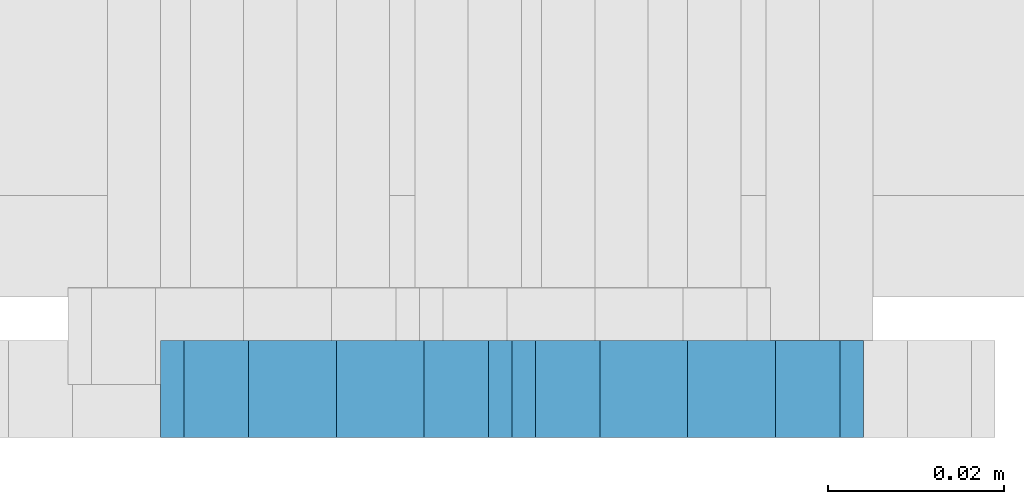
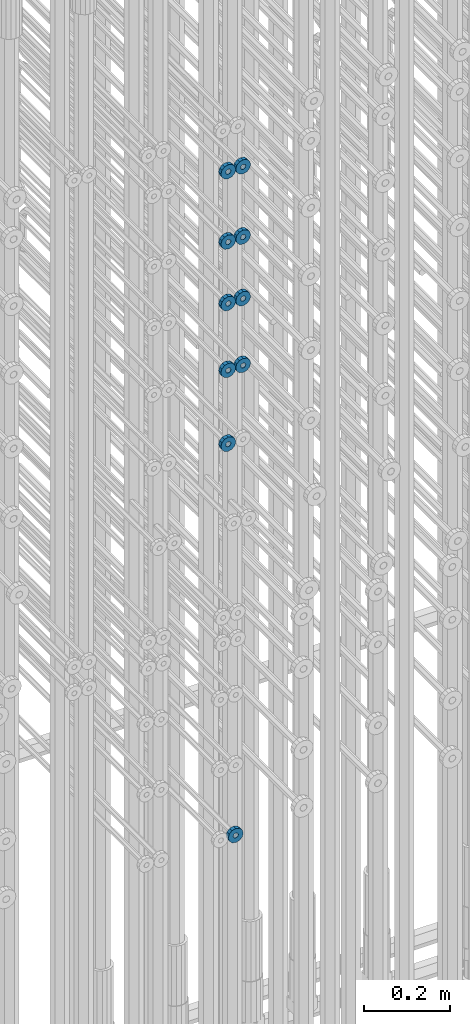
# One storey, part 135 of 177: 10 beams.
"""IFC2X3 building model written with IfcOpenShell, lengths in millimetres."""

from ifc_helpers import new_model, si_unit, frame, origin_with_axes, place, context, subcontext, project, spatial, faceted_brep, material, type_object, element, save


model = new_model("IFC2X3")

# Units and contexts
model_context_1 = context("Model", 3, precision=1e-05, world=origin_with_axes())
model_context_2 = context("Model", 3, precision=1e-05, world=origin_with_axes())
body_context = subcontext(model_context_2, "Body", "Model", "MODEL_VIEW")
ifc_project = project(units=[si_unit("LENGTHUNIT", "METRE", prefix="MILLI"), si_unit("AREAUNIT", "SQUARE_METRE"), si_unit("VOLUMEUNIT", "CUBIC_METRE"), si_unit("MASSUNIT", "GRAM", prefix="KILO"), si_unit("TIMEUNIT", "SECOND"), si_unit("PLANEANGLEUNIT", "RADIAN"), si_unit("SOLIDANGLEUNIT", "STERADIAN"), si_unit("THERMODYNAMICTEMPERATUREUNIT", "DEGREE_CELSIUS"), si_unit("LUMINOUSINTENSITYUNIT", "LUMEN")], contexts=[model_context_1])

# Site, building, storey
site_placement = place(None, origin_with_axes())
site = spatial("IfcSite", under=ifc_project, at=site_placement, CompositionType="ELEMENT")
building_placement = place(site_placement, origin_with_axes())
building = spatial("IfcBuilding", under=site, at=building_placement, Name="Undefined", CompositionType="ELEMENT")
storey_placement = place(building_placement, origin_with_axes())
storey = spatial("IfcBuildingStorey", under=building, at=storey_placement, Name="Undefined", CompositionType="ELEMENT", Elevation=0.0)

# Beams
ifc_material = material(Name="STEEL/Steel_Undefined")
beam_type = type_object("IfcBeamType", PredefinedType="NOTDEFINED")
beam_1_placement = place(storey_placement, frame((2031926.99847313, 6205070.98588034, 20239.9868114202), z_axis=(0.0, 0.0, -1.0), x_axis=(0.0, -1.0, 0.0)))
element("IfcBeam", 1, at=beam_1_placement, inside=storey, type_object=beam_type, material=ifc_material, context=body_context, shape_type="Brep", body=[
    faceted_brep([(-3.63797880709171e-12, -7.0, -2.3283064365387e-10), (-8.62348444298797e-13, -6.06217782649107, 3.5), (10.9999999999964, -6.06217782665044, 3.49999999976717), (10.9999999999964, -7.0, -2.3283064365387e-10), (-3.63797880709171e-12, -3.5, 6.06217782618478), (11.0, -3.5, 6.06217782618478), (-1.72469688859759e-12, 0.0, 7.0), (11.0, 0.0, 6.99999999976717), (-3.63797880709171e-12, 3.5, 6.06217782618478), (11.0, 3.5, 6.06217782618478), (-8.62348444298795e-13, 6.06217782649107, 3.5), (10.9999999999964, 6.06217782665044, 3.49999999976717), (-3.63797880709171e-12, 7.0, -2.3283064365387e-10), (10.9999999999964, 7.0, -2.3283064365387e-10), (8.62348444298797e-13, 6.06217782649107, -3.5), (10.9999999999964, 6.06217782665044, -3.50000000023283), (-3.63797880709171e-12, 3.5, -6.06217782665044), (10.9999999999964, 3.5, -6.06217782665044), (1.72469688859759e-12, -2.72004641033163e-15, -7.0), (10.9999999999964, 0.0, -7.00000000023283), (-3.63797880709171e-12, -3.5, -6.06217782665044), (10.9999999999964, -3.5, -6.06217782665044), (8.62348444298796e-13, -6.06217782649107, -3.5), (10.9999999999964, -6.06217782665044, -3.50000000023283), (0.0, -20.0000000009313, 0.0), (0.0, -17.320508075878, -10.0), (10.9999999999964, -17.320508075878, -10.0000000002328), (10.9999999999964, -20.0, -2.3283064365387e-10), (0.0, -10.0000000009313, -17.3205080756452), (11.0, -10.0, -17.320508075878), (0.0, -1.86264514923096e-09, -19.9999999998836), (10.9999999999964, 0.0, -20.0000000002328), (0.0, 9.99999999906868, -17.3205080755288), (11.0, 10.0, -17.320508075878), (0.0, 17.320508075878, -10.0), (10.9999999999964, 17.320508075878, -10.0000000002328), (0.0, 19.9999999990687, 0.0), (10.9999999999964, 20.0, -2.3283064365387e-10), (0.0, 17.3205080740154, 10.0), (11.0, 17.320508075878, 9.99999999976717), (0.0, 9.99999999906868, 17.3205080757616), (10.9999999999964, 10.0, 17.3205080754124), (0.0, 0.0, 20.0000000001164), (10.9999999999964, 0.0, 19.9999999997672), (0.0, -10.0000000009313, 17.3205080757616), (10.9999999999964, -10.0, 17.3205080754124), (0.0, -17.3205080777407, 10.0000000001164), (11.0, -17.320508075878, 9.99999999976717)], [[[0, 1, 2, 3]], [[1, 4, 5, 2]], [[4, 6, 7, 5]], [[6, 8, 9, 7]], [[8, 10, 11, 9]], [[10, 12, 13, 11]], [[12, 14, 15, 13]], [[14, 16, 17, 15]], [[16, 18, 19, 17]], [[18, 20, 21, 19]], [[20, 22, 23, 21]], [[22, 0, 3, 23]], [[24, 25, 26, 27]], [[25, 28, 29, 26]], [[28, 30, 31, 29]], [[30, 32, 33, 31]], [[32, 34, 35, 33]], [[34, 36, 37, 35]], [[36, 38, 39, 37]], [[38, 40, 41, 39]], [[40, 42, 43, 41]], [[42, 44, 45, 43]], [[44, 46, 47, 45]], [[46, 24, 27, 47]], [[29, 31, 33, 35, 37, 39, 41, 43, 45, 47, 27, 26], [5, 7, 9, 11, 13, 15, 17, 19, 21, 23, 3, 2]], [[46, 44, 42, 40, 38, 36, 34, 32, 30, 28, 25, 24], [22, 20, 18, 16, 14, 12, 10, 8, 6, 4, 1, 0]]]),
])
beam_2_placement = place(storey_placement, frame((2031906.99847313, 6205070.98588032, 22134.9868114202), z_axis=(0.0, 0.0, -1.0), x_axis=(0.0, -1.0, 0.0)))
element("IfcBeam", 2, at=beam_2_placement, inside=storey, type_object=beam_type, material=ifc_material, context=body_context, shape_type="Brep", body=[
    faceted_brep([(-3.63797880709171e-12, -7.0, -2.3283064365387e-10), (-8.62348444298797e-13, -6.06217782649107, 3.5), (10.9999999999964, -6.06217782665044, 3.49999999976717), (10.9999999999964, -7.0, -2.3283064365387e-10), (-3.63797880709171e-12, -3.5, 6.06217782618478), (11.0, -3.5, 6.06217782618478), (-1.72469688859759e-12, 0.0, 7.0), (11.0, 0.0, 6.99999999976717), (-3.63797880709171e-12, 3.5, 6.06217782618478), (11.0, 3.5, 6.06217782618478), (-8.62348444298795e-13, 6.06217782649107, 3.5), (10.9999999999964, 6.06217782665044, 3.49999999976717), (-3.63797880709171e-12, 7.0, -2.3283064365387e-10), (10.9999999999964, 7.0, -2.3283064365387e-10), (8.62348444298797e-13, 6.06217782649107, -3.5), (10.9999999999964, 6.06217782665044, -3.50000000023283), (-3.63797880709171e-12, 3.5, -6.06217782665044), (10.9999999999964, 3.5, -6.06217782665044), (1.72469688859759e-12, -2.72004641033163e-15, -7.0), (10.9999999999964, 0.0, -7.00000000023283), (-3.63797880709171e-12, -3.5, -6.06217782665044), (10.9999999999964, -3.5, -6.06217782665044), (8.62348444298796e-13, -6.06217782649107, -3.5), (10.9999999999964, -6.06217782665044, -3.50000000023283), (0.0, -20.0000000009313, 0.0), (0.0, -17.320508075878, -10.0), (10.9999999999964, -17.320508075878, -10.0000000002328), (10.9999999999964, -20.0, -2.3283064365387e-10), (0.0, -10.0000000009313, -17.3205080756452), (11.0, -10.0, -17.320508075878), (0.0, -1.86264514923096e-09, -19.9999999998836), (10.9999999999964, 0.0, -20.0000000002328), (0.0, 9.99999999906868, -17.3205080755288), (11.0, 10.0, -17.320508075878), (0.0, 17.320508075878, -10.0), (10.9999999999964, 17.320508075878, -10.0000000002328), (0.0, 19.9999999990687, 0.0), (10.9999999999964, 20.0, -2.3283064365387e-10), (0.0, 17.3205080740154, 10.0), (11.0, 17.320508075878, 9.99999999976717), (0.0, 9.99999999906868, 17.3205080757616), (10.9999999999964, 10.0, 17.3205080754124), (0.0, 0.0, 20.0000000001164), (10.9999999999964, 0.0, 19.9999999997672), (0.0, -10.0000000009313, 17.3205080757616), (10.9999999999964, -10.0, 17.3205080754124), (0.0, -17.3205080777407, 10.0000000001164), (11.0, -17.320508075878, 9.99999999976717)], [[[0, 1, 2, 3]], [[1, 4, 5, 2]], [[4, 6, 7, 5]], [[6, 8, 9, 7]], [[8, 10, 11, 9]], [[10, 12, 13, 11]], [[12, 14, 15, 13]], [[14, 16, 17, 15]], [[16, 18, 19, 17]], [[18, 20, 21, 19]], [[20, 22, 23, 21]], [[22, 0, 3, 23]], [[24, 25, 26, 27]], [[25, 28, 29, 26]], [[28, 30, 31, 29]], [[30, 32, 33, 31]], [[32, 34, 35, 33]], [[34, 36, 37, 35]], [[36, 38, 39, 37]], [[38, 40, 41, 39]], [[40, 42, 43, 41]], [[42, 44, 45, 43]], [[44, 46, 47, 45]], [[46, 24, 27, 47]], [[29, 31, 33, 35, 37, 39, 41, 43, 45, 47, 27, 26], [5, 7, 9, 11, 13, 15, 17, 19, 21, 23, 3, 2]], [[46, 44, 42, 40, 38, 36, 34, 32, 30, 28, 25, 24], [22, 20, 18, 16, 14, 12, 10, 8, 6, 4, 1, 0]]]),
])
beam_3_placement = place(storey_placement, frame((2031946.99847313, 6205070.98588032, 22134.9868114202), z_axis=(0.0, 0.0, -1.0), x_axis=(0.0, -1.0, 0.0)))
element("IfcBeam", 3, at=beam_3_placement, inside=storey, type_object=beam_type, material=ifc_material, context=body_context, shape_type="Brep", body=[
    faceted_brep([(-3.63797880709171e-12, -7.0, -2.3283064365387e-10), (-8.62348444298797e-13, -6.06217782649107, 3.5), (10.9999999999964, -6.06217782665044, 3.49999999976717), (10.9999999999964, -7.0, -2.3283064365387e-10), (-3.63797880709171e-12, -3.5, 6.06217782618478), (11.0, -3.5, 6.06217782618478), (-1.72469688859759e-12, 0.0, 7.0), (11.0, 0.0, 6.99999999976717), (-3.63797880709171e-12, 3.5, 6.06217782618478), (11.0, 3.5, 6.06217782618478), (-8.62348444298795e-13, 6.06217782649107, 3.5), (10.9999999999964, 6.06217782665044, 3.49999999976717), (-3.63797880709171e-12, 7.0, -2.3283064365387e-10), (10.9999999999964, 7.0, -2.3283064365387e-10), (8.62348444298797e-13, 6.06217782649107, -3.5), (10.9999999999964, 6.06217782665044, -3.50000000023283), (-3.63797880709171e-12, 3.5, -6.06217782665044), (10.9999999999964, 3.5, -6.06217782665044), (1.72469688859759e-12, -2.72004641033163e-15, -7.0), (10.9999999999964, 0.0, -7.00000000023283), (-3.63797880709171e-12, -3.5, -6.06217782665044), (10.9999999999964, -3.5, -6.06217782665044), (8.62348444298796e-13, -6.06217782649107, -3.5), (10.9999999999964, -6.06217782665044, -3.50000000023283), (0.0, -20.0000000009313, 0.0), (0.0, -17.320508075878, -10.0), (10.9999999999964, -17.320508075878, -10.0000000002328), (10.9999999999964, -20.0, -2.3283064365387e-10), (0.0, -10.0000000009313, -17.3205080756452), (11.0, -10.0, -17.320508075878), (0.0, -1.86264514923096e-09, -19.9999999998836), (10.9999999999964, 0.0, -20.0000000002328), (0.0, 9.99999999906868, -17.3205080755288), (11.0, 10.0, -17.320508075878), (0.0, 17.320508075878, -10.0), (10.9999999999964, 17.320508075878, -10.0000000002328), (0.0, 19.9999999990687, 0.0), (10.9999999999964, 20.0, -2.3283064365387e-10), (0.0, 17.3205080740154, 10.0), (11.0, 17.320508075878, 9.99999999976717), (0.0, 9.99999999906868, 17.3205080757616), (10.9999999999964, 10.0, 17.3205080754124), (0.0, 0.0, 20.0000000001164), (10.9999999999964, 0.0, 19.9999999997672), (0.0, -10.0000000009313, 17.3205080757616), (10.9999999999964, -10.0, 17.3205080754124), (0.0, -17.3205080777407, 10.0000000001164), (11.0, -17.320508075878, 9.99999999976717)], [[[0, 1, 2, 3]], [[1, 4, 5, 2]], [[4, 6, 7, 5]], [[6, 8, 9, 7]], [[8, 10, 11, 9]], [[10, 12, 13, 11]], [[12, 14, 15, 13]], [[14, 16, 17, 15]], [[16, 18, 19, 17]], [[18, 20, 21, 19]], [[20, 22, 23, 21]], [[22, 0, 3, 23]], [[24, 25, 26, 27]], [[25, 28, 29, 26]], [[28, 30, 31, 29]], [[30, 32, 33, 31]], [[32, 34, 35, 33]], [[34, 36, 37, 35]], [[36, 38, 39, 37]], [[38, 40, 41, 39]], [[40, 42, 43, 41]], [[42, 44, 45, 43]], [[44, 46, 47, 45]], [[46, 24, 27, 47]], [[29, 31, 33, 35, 37, 39, 41, 43, 45, 47, 27, 26], [5, 7, 9, 11, 13, 15, 17, 19, 21, 23, 3, 2]], [[46, 44, 42, 40, 38, 36, 34, 32, 30, 28, 25, 24], [22, 20, 18, 16, 14, 12, 10, 8, 6, 4, 1, 0]]]),
])
beam_4_placement = place(storey_placement, frame((2031946.99847313, 6205070.98588032, 21934.9868114202), z_axis=(0.0, 0.0, -1.0), x_axis=(0.0, -1.0, 0.0)))
element("IfcBeam", 4, at=beam_4_placement, inside=storey, type_object=beam_type, material=ifc_material, context=body_context, shape_type="Brep", body=[
    faceted_brep([(-3.63797880709171e-12, -7.0, -2.3283064365387e-10), (-8.62348444298797e-13, -6.06217782649107, 3.5), (10.9999999999964, -6.06217782665044, 3.49999999976717), (10.9999999999964, -7.0, -2.3283064365387e-10), (-3.63797880709171e-12, -3.5, 6.06217782618478), (11.0, -3.5, 6.06217782618478), (-1.72469688859759e-12, 0.0, 7.0), (11.0, 0.0, 6.99999999976717), (-3.63797880709171e-12, 3.5, 6.06217782618478), (11.0, 3.5, 6.06217782618478), (-8.62348444298795e-13, 6.06217782649107, 3.5), (10.9999999999964, 6.06217782665044, 3.49999999976717), (-3.63797880709171e-12, 7.0, -2.3283064365387e-10), (10.9999999999964, 7.0, -2.3283064365387e-10), (8.62348444298797e-13, 6.06217782649107, -3.5), (10.9999999999964, 6.06217782665044, -3.50000000023283), (-3.63797880709171e-12, 3.5, -6.06217782665044), (10.9999999999964, 3.5, -6.06217782665044), (1.72469688859759e-12, -2.72004641033163e-15, -7.0), (10.9999999999964, 0.0, -7.00000000023283), (-3.63797880709171e-12, -3.5, -6.06217782665044), (10.9999999999964, -3.5, -6.06217782665044), (8.62348444298796e-13, -6.06217782649107, -3.5), (10.9999999999964, -6.06217782665044, -3.50000000023283), (0.0, -20.0000000009313, 0.0), (0.0, -17.320508075878, -10.0), (10.9999999999964, -17.320508075878, -10.0000000002328), (10.9999999999964, -20.0, -2.3283064365387e-10), (0.0, -10.0000000009313, -17.3205080756452), (11.0, -10.0, -17.320508075878), (0.0, -1.86264514923096e-09, -19.9999999998836), (10.9999999999964, 0.0, -20.0000000002328), (0.0, 9.99999999906868, -17.3205080755288), (11.0, 10.0, -17.320508075878), (0.0, 17.320508075878, -10.0), (10.9999999999964, 17.320508075878, -10.0000000002328), (0.0, 19.9999999990687, 0.0), (10.9999999999964, 20.0, -2.3283064365387e-10), (0.0, 17.3205080740154, 10.0), (11.0, 17.320508075878, 9.99999999976717), (0.0, 9.99999999906868, 17.3205080757616), (10.9999999999964, 10.0, 17.3205080754124), (0.0, 0.0, 20.0000000001164), (10.9999999999964, 0.0, 19.9999999997672), (0.0, -10.0000000009313, 17.3205080757616), (10.9999999999964, -10.0, 17.3205080754124), (0.0, -17.3205080777407, 10.0000000001164), (11.0, -17.320508075878, 9.99999999976717)], [[[0, 1, 2, 3]], [[1, 4, 5, 2]], [[4, 6, 7, 5]], [[6, 8, 9, 7]], [[8, 10, 11, 9]], [[10, 12, 13, 11]], [[12, 14, 15, 13]], [[14, 16, 17, 15]], [[16, 18, 19, 17]], [[18, 20, 21, 19]], [[20, 22, 23, 21]], [[22, 0, 3, 23]], [[24, 25, 26, 27]], [[25, 28, 29, 26]], [[28, 30, 31, 29]], [[30, 32, 33, 31]], [[32, 34, 35, 33]], [[34, 36, 37, 35]], [[36, 38, 39, 37]], [[38, 40, 41, 39]], [[40, 42, 43, 41]], [[42, 44, 45, 43]], [[44, 46, 47, 45]], [[46, 24, 27, 47]], [[29, 31, 33, 35, 37, 39, 41, 43, 45, 47, 27, 26], [5, 7, 9, 11, 13, 15, 17, 19, 21, 23, 3, 2]], [[46, 44, 42, 40, 38, 36, 34, 32, 30, 28, 25, 24], [22, 20, 18, 16, 14, 12, 10, 8, 6, 4, 1, 0]]]),
])
beam_5_placement = place(storey_placement, frame((2031906.99847313, 6205070.98588032, 21934.9868114202), z_axis=(0.0, 0.0, -1.0), x_axis=(0.0, -1.0, 0.0)))
element("IfcBeam", 5, at=beam_5_placement, inside=storey, type_object=beam_type, material=ifc_material, context=body_context, shape_type="Brep", body=[
    faceted_brep([(-3.63797880709171e-12, -7.0, -2.3283064365387e-10), (-8.62348444298797e-13, -6.06217782649107, 3.5), (10.9999999999964, -6.06217782665044, 3.49999999976717), (10.9999999999964, -7.0, -2.3283064365387e-10), (-3.63797880709171e-12, -3.5, 6.06217782618478), (11.0, -3.5, 6.06217782618478), (-1.72469688859759e-12, 0.0, 7.0), (11.0, 0.0, 6.99999999976717), (-3.63797880709171e-12, 3.5, 6.06217782618478), (11.0, 3.5, 6.06217782618478), (-8.62348444298795e-13, 6.06217782649107, 3.5), (10.9999999999964, 6.06217782665044, 3.49999999976717), (-3.63797880709171e-12, 7.0, -2.3283064365387e-10), (10.9999999999964, 7.0, -2.3283064365387e-10), (8.62348444298797e-13, 6.06217782649107, -3.5), (10.9999999999964, 6.06217782665044, -3.50000000023283), (-3.63797880709171e-12, 3.5, -6.06217782665044), (10.9999999999964, 3.5, -6.06217782665044), (1.72469688859759e-12, -2.72004641033163e-15, -7.0), (10.9999999999964, 0.0, -7.00000000023283), (-3.63797880709171e-12, -3.5, -6.06217782665044), (10.9999999999964, -3.5, -6.06217782665044), (8.62348444298796e-13, -6.06217782649107, -3.5), (10.9999999999964, -6.06217782665044, -3.50000000023283), (0.0, -20.0000000009313, 0.0), (0.0, -17.320508075878, -10.0), (10.9999999999964, -17.320508075878, -10.0000000002328), (10.9999999999964, -20.0, -2.3283064365387e-10), (0.0, -10.0000000009313, -17.3205080756452), (11.0, -10.0, -17.320508075878), (0.0, -1.86264514923096e-09, -19.9999999998836), (10.9999999999964, 0.0, -20.0000000002328), (0.0, 9.99999999906868, -17.3205080755288), (11.0, 10.0, -17.320508075878), (0.0, 17.320508075878, -10.0), (10.9999999999964, 17.320508075878, -10.0000000002328), (0.0, 19.9999999990687, 0.0), (10.9999999999964, 20.0, -2.3283064365387e-10), (0.0, 17.3205080740154, 10.0), (11.0, 17.320508075878, 9.99999999976717), (0.0, 9.99999999906868, 17.3205080757616), (10.9999999999964, 10.0, 17.3205080754124), (0.0, 0.0, 20.0000000001164), (10.9999999999964, 0.0, 19.9999999997672), (0.0, -10.0000000009313, 17.3205080757616), (10.9999999999964, -10.0, 17.3205080754124), (0.0, -17.3205080777407, 10.0000000001164), (11.0, -17.320508075878, 9.99999999976717)], [[[0, 1, 2, 3]], [[1, 4, 5, 2]], [[4, 6, 7, 5]], [[6, 8, 9, 7]], [[8, 10, 11, 9]], [[10, 12, 13, 11]], [[12, 14, 15, 13]], [[14, 16, 17, 15]], [[16, 18, 19, 17]], [[18, 20, 21, 19]], [[20, 22, 23, 21]], [[22, 0, 3, 23]], [[24, 25, 26, 27]], [[25, 28, 29, 26]], [[28, 30, 31, 29]], [[30, 32, 33, 31]], [[32, 34, 35, 33]], [[34, 36, 37, 35]], [[36, 38, 39, 37]], [[38, 40, 41, 39]], [[40, 42, 43, 41]], [[42, 44, 45, 43]], [[44, 46, 47, 45]], [[46, 24, 27, 47]], [[29, 31, 33, 35, 37, 39, 41, 43, 45, 47, 27, 26], [5, 7, 9, 11, 13, 15, 17, 19, 21, 23, 3, 2]], [[46, 44, 42, 40, 38, 36, 34, 32, 30, 28, 25, 24], [22, 20, 18, 16, 14, 12, 10, 8, 6, 4, 1, 0]]]),
])
beam_6_placement = place(storey_placement, frame((2031906.99847313, 6205070.98588032, 21759.9868114202), z_axis=(0.0, 0.0, -1.0), x_axis=(0.0, -1.0, 0.0)))
element("IfcBeam", 6, at=beam_6_placement, inside=storey, type_object=beam_type, material=ifc_material, context=body_context, shape_type="Brep", body=[
    faceted_brep([(-3.63797880709171e-12, -7.0, -2.3283064365387e-10), (-8.62348444298797e-13, -6.06217782649107, 3.5), (10.9999999999964, -6.06217782665044, 3.49999999976717), (10.9999999999964, -7.0, -2.3283064365387e-10), (-3.63797880709171e-12, -3.5, 6.06217782618478), (11.0, -3.5, 6.06217782618478), (-1.72469688859759e-12, 0.0, 7.0), (11.0, 0.0, 6.99999999976717), (-3.63797880709171e-12, 3.5, 6.06217782618478), (11.0, 3.5, 6.06217782618478), (-8.62348444298795e-13, 6.06217782649107, 3.5), (10.9999999999964, 6.06217782665044, 3.49999999976717), (-3.63797880709171e-12, 7.0, -2.3283064365387e-10), (10.9999999999964, 7.0, -2.3283064365387e-10), (8.62348444298797e-13, 6.06217782649107, -3.5), (10.9999999999964, 6.06217782665044, -3.50000000023283), (-3.63797880709171e-12, 3.5, -6.06217782665044), (10.9999999999964, 3.5, -6.06217782665044), (1.72469688859759e-12, -2.72004641033163e-15, -7.0), (10.9999999999964, 0.0, -7.00000000023283), (-3.63797880709171e-12, -3.5, -6.06217782665044), (10.9999999999964, -3.5, -6.06217782665044), (8.62348444298796e-13, -6.06217782649107, -3.5), (10.9999999999964, -6.06217782665044, -3.50000000023283), (0.0, -20.0000000009313, 0.0), (0.0, -17.320508075878, -10.0), (10.9999999999964, -17.320508075878, -10.0000000002328), (10.9999999999964, -20.0, -2.3283064365387e-10), (0.0, -10.0000000009313, -17.3205080756452), (11.0, -10.0, -17.320508075878), (0.0, -1.86264514923096e-09, -19.9999999998836), (10.9999999999964, 0.0, -20.0000000002328), (0.0, 9.99999999906868, -17.3205080755288), (11.0, 10.0, -17.320508075878), (0.0, 17.320508075878, -10.0), (10.9999999999964, 17.320508075878, -10.0000000002328), (0.0, 19.9999999990687, 0.0), (10.9999999999964, 20.0, -2.3283064365387e-10), (0.0, 17.3205080740154, 10.0), (11.0, 17.320508075878, 9.99999999976717), (0.0, 9.99999999906868, 17.3205080757616), (10.9999999999964, 10.0, 17.3205080754124), (0.0, 0.0, 20.0000000001164), (10.9999999999964, 0.0, 19.9999999997672), (0.0, -10.0000000009313, 17.3205080757616), (10.9999999999964, -10.0, 17.3205080754124), (0.0, -17.3205080777407, 10.0000000001164), (11.0, -17.320508075878, 9.99999999976717)], [[[0, 1, 2, 3]], [[1, 4, 5, 2]], [[4, 6, 7, 5]], [[6, 8, 9, 7]], [[8, 10, 11, 9]], [[10, 12, 13, 11]], [[12, 14, 15, 13]], [[14, 16, 17, 15]], [[16, 18, 19, 17]], [[18, 20, 21, 19]], [[20, 22, 23, 21]], [[22, 0, 3, 23]], [[24, 25, 26, 27]], [[25, 28, 29, 26]], [[28, 30, 31, 29]], [[30, 32, 33, 31]], [[32, 34, 35, 33]], [[34, 36, 37, 35]], [[36, 38, 39, 37]], [[38, 40, 41, 39]], [[40, 42, 43, 41]], [[42, 44, 45, 43]], [[44, 46, 47, 45]], [[46, 24, 27, 47]], [[29, 31, 33, 35, 37, 39, 41, 43, 45, 47, 27, 26], [5, 7, 9, 11, 13, 15, 17, 19, 21, 23, 3, 2]], [[46, 44, 42, 40, 38, 36, 34, 32, 30, 28, 25, 24], [22, 20, 18, 16, 14, 12, 10, 8, 6, 4, 1, 0]]]),
])
beam_7_placement = place(storey_placement, frame((2031946.99847313, 6205070.98588032, 21759.9868114202), z_axis=(0.0, 0.0, -1.0), x_axis=(0.0, -1.0, 0.0)))
element("IfcBeam", 7, at=beam_7_placement, inside=storey, type_object=beam_type, material=ifc_material, context=body_context, shape_type="Brep", body=[
    faceted_brep([(-3.63797880709171e-12, -7.0, -2.3283064365387e-10), (-8.62348444298797e-13, -6.06217782649107, 3.5), (10.9999999999964, -6.06217782665044, 3.49999999976717), (10.9999999999964, -7.0, -2.3283064365387e-10), (-3.63797880709171e-12, -3.5, 6.06217782618478), (11.0, -3.5, 6.06217782618478), (-1.72469688859759e-12, 0.0, 7.0), (11.0, 0.0, 6.99999999976717), (-3.63797880709171e-12, 3.5, 6.06217782618478), (11.0, 3.5, 6.06217782618478), (-8.62348444298795e-13, 6.06217782649107, 3.5), (10.9999999999964, 6.06217782665044, 3.49999999976717), (-3.63797880709171e-12, 7.0, -2.3283064365387e-10), (10.9999999999964, 7.0, -2.3283064365387e-10), (8.62348444298797e-13, 6.06217782649107, -3.5), (10.9999999999964, 6.06217782665044, -3.50000000023283), (-3.63797880709171e-12, 3.5, -6.06217782665044), (10.9999999999964, 3.5, -6.06217782665044), (1.72469688859759e-12, -2.72004641033163e-15, -7.0), (10.9999999999964, 0.0, -7.00000000023283), (-3.63797880709171e-12, -3.5, -6.06217782665044), (10.9999999999964, -3.5, -6.06217782665044), (8.62348444298796e-13, -6.06217782649107, -3.5), (10.9999999999964, -6.06217782665044, -3.50000000023283), (0.0, -20.0000000009313, 0.0), (0.0, -17.320508075878, -10.0), (10.9999999999964, -17.320508075878, -10.0000000002328), (10.9999999999964, -20.0, -2.3283064365387e-10), (0.0, -10.0000000009313, -17.3205080756452), (11.0, -10.0, -17.320508075878), (0.0, -1.86264514923096e-09, -19.9999999998836), (10.9999999999964, 0.0, -20.0000000002328), (0.0, 9.99999999906868, -17.3205080755288), (11.0, 10.0, -17.320508075878), (0.0, 17.320508075878, -10.0), (10.9999999999964, 17.320508075878, -10.0000000002328), (0.0, 19.9999999990687, 0.0), (10.9999999999964, 20.0, -2.3283064365387e-10), (0.0, 17.3205080740154, 10.0), (11.0, 17.320508075878, 9.99999999976717), (0.0, 9.99999999906868, 17.3205080757616), (10.9999999999964, 10.0, 17.3205080754124), (0.0, 0.0, 20.0000000001164), (10.9999999999964, 0.0, 19.9999999997672), (0.0, -10.0000000009313, 17.3205080757616), (10.9999999999964, -10.0, 17.3205080754124), (0.0, -17.3205080777407, 10.0000000001164), (11.0, -17.320508075878, 9.99999999976717)], [[[0, 1, 2, 3]], [[1, 4, 5, 2]], [[4, 6, 7, 5]], [[6, 8, 9, 7]], [[8, 10, 11, 9]], [[10, 12, 13, 11]], [[12, 14, 15, 13]], [[14, 16, 17, 15]], [[16, 18, 19, 17]], [[18, 20, 21, 19]], [[20, 22, 23, 21]], [[22, 0, 3, 23]], [[24, 25, 26, 27]], [[25, 28, 29, 26]], [[28, 30, 31, 29]], [[30, 32, 33, 31]], [[32, 34, 35, 33]], [[34, 36, 37, 35]], [[36, 38, 39, 37]], [[38, 40, 41, 39]], [[40, 42, 43, 41]], [[42, 44, 45, 43]], [[44, 46, 47, 45]], [[46, 24, 27, 47]], [[29, 31, 33, 35, 37, 39, 41, 43, 45, 47, 27, 26], [5, 7, 9, 11, 13, 15, 17, 19, 21, 23, 3, 2]], [[46, 44, 42, 40, 38, 36, 34, 32, 30, 28, 25, 24], [22, 20, 18, 16, 14, 12, 10, 8, 6, 4, 1, 0]]]),
])
beam_8_placement = place(storey_placement, frame((2031946.99847313, 6205070.98588032, 21569.9868114202), z_axis=(0.0, 0.0, -1.0), x_axis=(0.0, -1.0, 0.0)))
element("IfcBeam", 8, at=beam_8_placement, inside=storey, type_object=beam_type, material=ifc_material, context=body_context, shape_type="Brep", body=[
    faceted_brep([(-3.63797880709171e-12, -7.0, -2.3283064365387e-10), (-8.62348444298797e-13, -6.06217782649107, 3.5), (10.9999999999964, -6.06217782665044, 3.49999999976717), (10.9999999999964, -7.0, -2.3283064365387e-10), (-3.63797880709171e-12, -3.5, 6.06217782618478), (11.0, -3.5, 6.06217782618478), (-1.72469688859759e-12, 0.0, 7.0), (11.0, 0.0, 6.99999999976717), (-3.63797880709171e-12, 3.5, 6.06217782618478), (11.0, 3.5, 6.06217782618478), (-8.62348444298795e-13, 6.06217782649107, 3.5), (10.9999999999964, 6.06217782665044, 3.49999999976717), (-3.63797880709171e-12, 7.0, -2.3283064365387e-10), (10.9999999999964, 7.0, -2.3283064365387e-10), (8.62348444298797e-13, 6.06217782649107, -3.5), (10.9999999999964, 6.06217782665044, -3.50000000023283), (-3.63797880709171e-12, 3.5, -6.06217782665044), (10.9999999999964, 3.5, -6.06217782665044), (1.72469688859759e-12, -2.72004641033163e-15, -7.0), (10.9999999999964, 0.0, -7.00000000023283), (-3.63797880709171e-12, -3.5, -6.06217782665044), (10.9999999999964, -3.5, -6.06217782665044), (8.62348444298796e-13, -6.06217782649107, -3.5), (10.9999999999964, -6.06217782665044, -3.50000000023283), (0.0, -20.0000000009313, 0.0), (0.0, -17.320508075878, -10.0), (10.9999999999964, -17.320508075878, -10.0000000002328), (10.9999999999964, -20.0, -2.3283064365387e-10), (0.0, -10.0000000009313, -17.3205080756452), (11.0, -10.0, -17.320508075878), (0.0, -1.86264514923096e-09, -19.9999999998836), (10.9999999999964, 0.0, -20.0000000002328), (0.0, 9.99999999906868, -17.3205080755288), (11.0, 10.0, -17.320508075878), (0.0, 17.320508075878, -10.0), (10.9999999999964, 17.320508075878, -10.0000000002328), (0.0, 19.9999999990687, 0.0), (10.9999999999964, 20.0, -2.3283064365387e-10), (0.0, 17.3205080740154, 10.0), (11.0, 17.320508075878, 9.99999999976717), (0.0, 9.99999999906868, 17.3205080757616), (10.9999999999964, 10.0, 17.3205080754124), (0.0, 0.0, 20.0000000001164), (10.9999999999964, 0.0, 19.9999999997672), (0.0, -10.0000000009313, 17.3205080757616), (10.9999999999964, -10.0, 17.3205080754124), (0.0, -17.3205080777407, 10.0000000001164), (11.0, -17.320508075878, 9.99999999976717)], [[[0, 1, 2, 3]], [[1, 4, 5, 2]], [[4, 6, 7, 5]], [[6, 8, 9, 7]], [[8, 10, 11, 9]], [[10, 12, 13, 11]], [[12, 14, 15, 13]], [[14, 16, 17, 15]], [[16, 18, 19, 17]], [[18, 20, 21, 19]], [[20, 22, 23, 21]], [[22, 0, 3, 23]], [[24, 25, 26, 27]], [[25, 28, 29, 26]], [[28, 30, 31, 29]], [[30, 32, 33, 31]], [[32, 34, 35, 33]], [[34, 36, 37, 35]], [[36, 38, 39, 37]], [[38, 40, 41, 39]], [[40, 42, 43, 41]], [[42, 44, 45, 43]], [[44, 46, 47, 45]], [[46, 24, 27, 47]], [[29, 31, 33, 35, 37, 39, 41, 43, 45, 47, 27, 26], [5, 7, 9, 11, 13, 15, 17, 19, 21, 23, 3, 2]], [[46, 44, 42, 40, 38, 36, 34, 32, 30, 28, 25, 24], [22, 20, 18, 16, 14, 12, 10, 8, 6, 4, 1, 0]]]),
])
beam_9_placement = place(storey_placement, frame((2031906.99847313, 6205070.98588032, 21569.9868114202), z_axis=(0.0, 0.0, -1.0), x_axis=(0.0, -1.0, 0.0)))
element("IfcBeam", 9, at=beam_9_placement, inside=storey, type_object=beam_type, material=ifc_material, context=body_context, shape_type="Brep", body=[
    faceted_brep([(-3.63797880709171e-12, -7.0, -2.3283064365387e-10), (-8.62348444298797e-13, -6.06217782649107, 3.5), (10.9999999999964, -6.06217782665044, 3.49999999976717), (10.9999999999964, -7.0, -2.3283064365387e-10), (-3.63797880709171e-12, -3.5, 6.06217782618478), (11.0, -3.5, 6.06217782618478), (-1.72469688859759e-12, 0.0, 7.0), (11.0, 0.0, 6.99999999976717), (-3.63797880709171e-12, 3.5, 6.06217782618478), (11.0, 3.5, 6.06217782618478), (-8.62348444298795e-13, 6.06217782649107, 3.5), (10.9999999999964, 6.06217782665044, 3.49999999976717), (-3.63797880709171e-12, 7.0, -2.3283064365387e-10), (10.9999999999964, 7.0, -2.3283064365387e-10), (8.62348444298797e-13, 6.06217782649107, -3.5), (10.9999999999964, 6.06217782665044, -3.50000000023283), (-3.63797880709171e-12, 3.5, -6.06217782665044), (10.9999999999964, 3.5, -6.06217782665044), (1.72469688859759e-12, -2.72004641033163e-15, -7.0), (10.9999999999964, 0.0, -7.00000000023283), (-3.63797880709171e-12, -3.5, -6.06217782665044), (10.9999999999964, -3.5, -6.06217782665044), (8.62348444298796e-13, -6.06217782649107, -3.5), (10.9999999999964, -6.06217782665044, -3.50000000023283), (0.0, -20.0000000009313, 0.0), (0.0, -17.320508075878, -10.0), (10.9999999999964, -17.320508075878, -10.0000000002328), (10.9999999999964, -20.0, -2.3283064365387e-10), (0.0, -10.0000000009313, -17.3205080756452), (11.0, -10.0, -17.320508075878), (0.0, -1.86264514923096e-09, -19.9999999998836), (10.9999999999964, 0.0, -20.0000000002328), (0.0, 9.99999999906868, -17.3205080755288), (11.0, 10.0, -17.320508075878), (0.0, 17.320508075878, -10.0), (10.9999999999964, 17.320508075878, -10.0000000002328), (0.0, 19.9999999990687, 0.0), (10.9999999999964, 20.0, -2.3283064365387e-10), (0.0, 17.3205080740154, 10.0), (11.0, 17.320508075878, 9.99999999976717), (0.0, 9.99999999906868, 17.3205080757616), (10.9999999999964, 10.0, 17.3205080754124), (0.0, 0.0, 20.0000000001164), (10.9999999999964, 0.0, 19.9999999997672), (0.0, -10.0000000009313, 17.3205080757616), (10.9999999999964, -10.0, 17.3205080754124), (0.0, -17.3205080777407, 10.0000000001164), (11.0, -17.320508075878, 9.99999999976717)], [[[0, 1, 2, 3]], [[1, 4, 5, 2]], [[4, 6, 7, 5]], [[6, 8, 9, 7]], [[8, 10, 11, 9]], [[10, 12, 13, 11]], [[12, 14, 15, 13]], [[14, 16, 17, 15]], [[16, 18, 19, 17]], [[18, 20, 21, 19]], [[20, 22, 23, 21]], [[22, 0, 3, 23]], [[24, 25, 26, 27]], [[25, 28, 29, 26]], [[28, 30, 31, 29]], [[30, 32, 33, 31]], [[32, 34, 35, 33]], [[34, 36, 37, 35]], [[36, 38, 39, 37]], [[38, 40, 41, 39]], [[40, 42, 43, 41]], [[42, 44, 45, 43]], [[44, 46, 47, 45]], [[46, 24, 27, 47]], [[29, 31, 33, 35, 37, 39, 41, 43, 45, 47, 27, 26], [5, 7, 9, 11, 13, 15, 17, 19, 21, 23, 3, 2]], [[46, 44, 42, 40, 38, 36, 34, 32, 30, 28, 25, 24], [22, 20, 18, 16, 14, 12, 10, 8, 6, 4, 1, 0]]]),
])
beam_10_placement = place(storey_placement, frame((2031906.99847313, 6205070.98588033, 21359.9868114202), z_axis=(0.0, 0.0, -1.0), x_axis=(0.0, -1.0, 0.0)))
element("IfcBeam", 10, at=beam_10_placement, inside=storey, type_object=beam_type, material=ifc_material, context=body_context, shape_type="Brep", body=[
    faceted_brep([(-3.63797880709171e-12, -7.0, -2.3283064365387e-10), (-8.62348444298797e-13, -6.06217782649107, 3.5), (10.9999999999964, -6.06217782665044, 3.49999999976717), (10.9999999999964, -7.0, -2.3283064365387e-10), (-3.63797880709171e-12, -3.5, 6.06217782618478), (11.0, -3.5, 6.06217782618478), (-1.72469688859759e-12, 0.0, 7.0), (11.0, 0.0, 6.99999999976717), (-3.63797880709171e-12, 3.5, 6.06217782618478), (11.0, 3.5, 6.06217782618478), (-8.62348444298795e-13, 6.06217782649107, 3.5), (10.9999999999964, 6.06217782665044, 3.49999999976717), (-3.63797880709171e-12, 7.0, -2.3283064365387e-10), (10.9999999999964, 7.0, -2.3283064365387e-10), (8.62348444298797e-13, 6.06217782649107, -3.5), (10.9999999999964, 6.06217782665044, -3.50000000023283), (-3.63797880709171e-12, 3.5, -6.06217782665044), (10.9999999999964, 3.5, -6.06217782665044), (1.72469688859759e-12, -2.72004641033163e-15, -7.0), (10.9999999999964, 0.0, -7.00000000023283), (-3.63797880709171e-12, -3.5, -6.06217782665044), (10.9999999999964, -3.5, -6.06217782665044), (8.62348444298796e-13, -6.06217782649107, -3.5), (10.9999999999964, -6.06217782665044, -3.50000000023283), (0.0, -20.0000000009313, 0.0), (0.0, -17.320508075878, -10.0), (10.9999999999964, -17.320508075878, -10.0000000002328), (10.9999999999964, -20.0, -2.3283064365387e-10), (0.0, -10.0000000009313, -17.3205080756452), (11.0, -10.0, -17.320508075878), (0.0, -1.86264514923096e-09, -19.9999999998836), (10.9999999999964, 0.0, -20.0000000002328), (0.0, 9.99999999906868, -17.3205080755288), (11.0, 10.0, -17.320508075878), (0.0, 17.320508075878, -10.0), (10.9999999999964, 17.320508075878, -10.0000000002328), (0.0, 19.9999999990687, 0.0), (10.9999999999964, 20.0, -2.3283064365387e-10), (0.0, 17.3205080740154, 10.0), (11.0, 17.320508075878, 9.99999999976717), (0.0, 9.99999999906868, 17.3205080757616), (10.9999999999964, 10.0, 17.3205080754124), (0.0, 0.0, 20.0000000001164), (10.9999999999964, 0.0, 19.9999999997672), (0.0, -10.0000000009313, 17.3205080757616), (10.9999999999964, -10.0, 17.3205080754124), (0.0, -17.3205080777407, 10.0000000001164), (11.0, -17.320508075878, 9.99999999976717)], [[[0, 1, 2, 3]], [[1, 4, 5, 2]], [[4, 6, 7, 5]], [[6, 8, 9, 7]], [[8, 10, 11, 9]], [[10, 12, 13, 11]], [[12, 14, 15, 13]], [[14, 16, 17, 15]], [[16, 18, 19, 17]], [[18, 20, 21, 19]], [[20, 22, 23, 21]], [[22, 0, 3, 23]], [[24, 25, 26, 27]], [[25, 28, 29, 26]], [[28, 30, 31, 29]], [[30, 32, 33, 31]], [[32, 34, 35, 33]], [[34, 36, 37, 35]], [[36, 38, 39, 37]], [[38, 40, 41, 39]], [[40, 42, 43, 41]], [[42, 44, 45, 43]], [[44, 46, 47, 45]], [[46, 24, 27, 47]], [[29, 31, 33, 35, 37, 39, 41, 43, 45, 47, 27, 26], [5, 7, 9, 11, 13, 15, 17, 19, 21, 23, 3, 2]], [[46, 44, 42, 40, 38, 36, 34, 32, 30, 28, 25, 24], [22, 20, 18, 16, 14, 12, 10, 8, 6, 4, 1, 0]]]),
])

save(model, "model.ifc")
